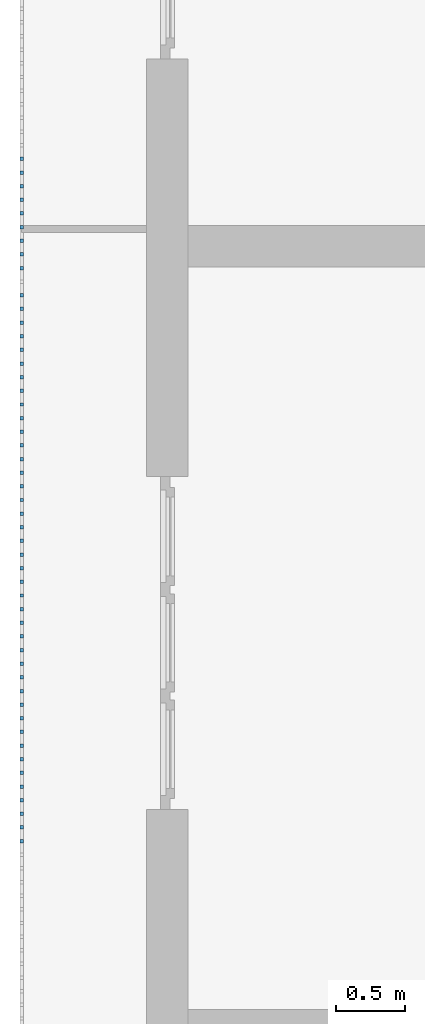
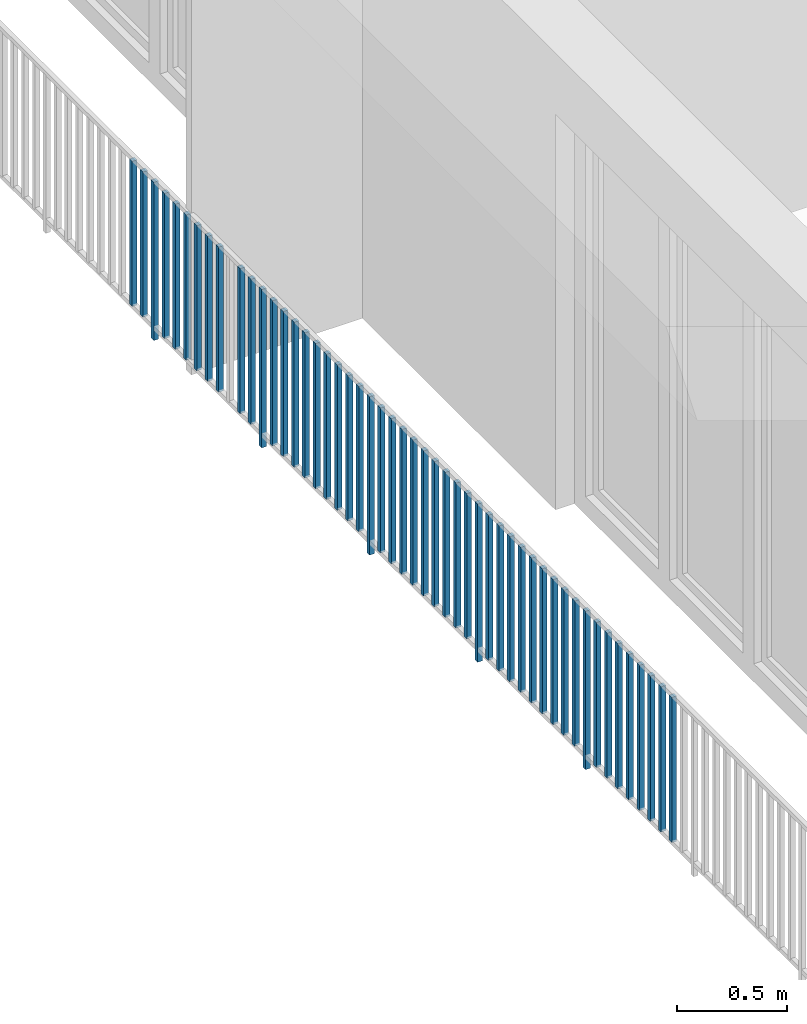
# One storey, part 37 of 54: 50 building element parts, 1 element without a shape of its own.
"""IFC4 building model written with IfcOpenShell, lengths in metres."""

import ifcopenshell
import ifcopenshell.guid

model = None  # the IFC model being written
_history = None  # IfcOwnerHistory: only IFC2X3 demands one
_inside = {}  # id of a spatial element -> (the spatial element, [elements in it])
_under = {}  # id of a project, library or spatial element -> (it, [spatial elements below it])
_declared = {}  # id of a project -> (the project, [libraries it declares])
_typed = {}  # id of a type object -> (the type object, [elements of that type])
_made_of = {}  # id of a material, layer set ... -> (it, [elements and type objects made of it])


def new_model(schema):
    """Start an empty IFC model of exactly this schema.

    Asked for "IFC4X3", IfcOpenShell would pick the latest addendum, in which some entities
    have other attributes; the version numbers below select the first issue.
    IFC2X3 requires an IfcOwnerHistory on every rooted entity: one is made here for all.
    """
    global model, _history
    if schema == "IFC4X3":
        model = ifcopenshell.file(schema_version=(4, 3, 0, 0))
    else:
        model = ifcopenshell.file(schema=schema)
    _inside.clear()
    _under.clear()
    _declared.clear()
    _typed.clear()
    _made_of.clear()
    _history = None
    if model.schema == "IFC2X3":
        org = make("IfcOrganization", Name="unknown")
        user = make(
            "IfcPersonAndOrganization",
            ThePerson=make("IfcPerson", FamilyName="unknown"),
            TheOrganization=org,
        )
        app = make(
            "IfcApplication",
            ApplicationDeveloper=org,
            Version="unknown",
            ApplicationFullName="unknown",
            ApplicationIdentifier="unknown",
        )
        _history = make(
            "IfcOwnerHistory",
            OwningUser=user,
            OwningApplication=app,
            ChangeAction="ADDED",
            CreationDate=0,
        )
    return model


def make(cls, **values):
    """One entity of the class cls with the attributes given. An attribute that is None is left unset."""
    return model.create_entity(
        cls, **{name: value for name, value in values.items() if value is not None}
    )


def entity(cls, *values):
    """Any entity or typed value of the class cls, its attributes in the order of the schema. None: left unset."""
    e = model.create_entity(cls)
    for i, value in enumerate(values):
        if value is not None:
            e[i] = value
    return e


def rooted(cls, **values):
    """An entity with a GlobalId (a new one), such as an element, a storey or a relation."""
    return make(cls, GlobalId=ifcopenshell.guid.new(), OwnerHistory=_history, **values)


def si_unit(unit_type, name, prefix=None):
    """IfcSIUnit, for example si_unit("LENGTHUNIT", "METRE", prefix="MILLI")."""
    return make("IfcSIUnit", UnitType=unit_type, Prefix=prefix, Name=name)


def converted_unit(unit_type, name, factor, base, dimensions=None, offset=None):
    """IfcConversionBasedUnit, such as the inch: factor (a typed value) times the base unit."""
    return make(
        "IfcConversionBasedUnit"
        if offset is None
        else "IfcConversionBasedUnitWithOffset",
        ConversionOffset=offset,
        Dimensions=None
        if dimensions is None
        else entity("IfcDimensionalExponents", *dimensions),
        UnitType=unit_type,
        Name=name,
        ConversionFactor=make(
            "IfcMeasureWithUnit", ValueComponent=factor, UnitComponent=base
        ),
    )


def derived_unit(unit_type, elements):
    """IfcDerivedUnit: a product of units, each with its exponent."""
    return make(
        "IfcDerivedUnit",
        Elements=[
            make("IfcDerivedUnitElement", Unit=unit, Exponent=power)
            for unit, power in elements
        ],
        UnitType=unit_type,
    )


def assignment(units):
    """IfcUnitAssignment: the units of a project."""
    return None if units is None else make("IfcUnitAssignment", Units=units)


def point(xyz):
    """IfcCartesianPoint."""
    return None if xyz is None else make("IfcCartesianPoint", Coordinates=xyz)


def direction(xyz):
    """IfcDirection."""
    return None if xyz is None else make("IfcDirection", DirectionRatios=xyz)


def frame(location, z_axis=None, x_axis=None):
    """IfcAxis2Placement3D, a coordinate frame: its origin and axes. An axis left out is left unset."""
    return make(
        "IfcAxis2Placement3D",
        Location=point(location),
        Axis=direction(z_axis),
        RefDirection=direction(x_axis),
    )


def origin_with_axes():
    """The frame at (0, 0, 0) with the z axis (0, 0, 1) and the x axis (1, 0, 0) written out."""
    return frame((0.0, 0.0, 0.0), z_axis=(0.0, 0.0, 1.0), x_axis=(1.0, 0.0, 0.0))


def place(relative_to, where):
    """IfcLocalPlacement: puts the frame where relative to a parent placement (None: the world)."""
    return make(
        "IfcLocalPlacement", PlacementRelTo=relative_to, RelativePlacement=where
    )


def context(
    kind, dimensions, precision=None, world=None, true_north=None, identifier=None
):
    """IfcGeometricRepresentationContext, for example the 3D "Model" context."""
    return make(
        "IfcGeometricRepresentationContext",
        ContextIdentifier=identifier,
        ContextType=kind,
        CoordinateSpaceDimension=dimensions,
        Precision=precision,
        WorldCoordinateSystem=world,
        TrueNorth=true_north,
    )


def subcontext(parent, identifier, kind, view, scale=None):
    """IfcGeometricRepresentationSubContext, for example "Body" below "Model"."""
    return make(
        "IfcGeometricRepresentationSubContext",
        ContextIdentifier=identifier,
        ContextType=kind,
        ParentContext=parent,
        TargetScale=scale,
        TargetView=view,
    )


def project(units=None, contexts=None):
    """IfcProject with its units and contexts."""
    return rooted(
        "IfcProject",
        Name="project",
        RepresentationContexts=contexts,
        UnitsInContext=assignment(units),
    )


def spatial(cls, under=None, at=None, **own):
    """A site, building, storey or space (cls), placed at a placement, below another one or the project."""
    s = rooted(cls, ObjectPlacement=at, **own)
    if under is not None:
        _under.setdefault(under.id(), (under, []))[1].append(s)
    return s


def point_list(points):
    """IfcCartesianPointList2D or 3D."""
    cls = (
        "IfcCartesianPointList2D" if len(points[0]) == 2 else "IfcCartesianPointList3D"
    )
    return make(cls, CoordList=points)


def polygons(points, faces, closed=None, point_numbers=None):
    """IfcPolygonalFaceSet: a face is its outer loop, then its inner loops; points numbered from 1."""
    made = []
    for loops in faces:
        if len(loops) == 1:
            made.append(make("IfcIndexedPolygonalFace", CoordIndex=loops[0]))
        else:
            made.append(
                make(
                    "IfcIndexedPolygonalFaceWithVoids",
                    CoordIndex=loops[0],
                    InnerCoordIndices=loops[1:],
                )
            )
    return make(
        "IfcPolygonalFaceSet",
        Coordinates=point_list(points),
        Closed=closed,
        Faces=made,
        PnIndex=point_numbers,
    )


def shape(context_of_items, identifier, shape_type, items):
    """IfcShapeRepresentation: the items that make up one representation, for example the "Body"."""
    return make(
        "IfcShapeRepresentation",
        ContextOfItems=context_of_items,
        RepresentationIdentifier=identifier,
        RepresentationType=shape_type,
        Items=items,
    )


def material(Name=None, Category=None):
    """IfcMaterial."""
    return make("IfcMaterial", Name=Name, Category=Category)


def made_of(thing, what):
    """Note that an element or type object is made of a material, layer set ...; save() writes the relation."""
    if what is not None:
        _made_of.setdefault(what.id(), (what, []))[1].append(thing)
    return thing


def type_object(cls, material=None, **own):
    """A type object (cls), such as IfcWallType, which elements share."""
    return made_of(rooted(cls, **own), material)


def element(
    cls,
    number,
    at=None,
    inside=None,
    cuts=None,
    type_object=None,
    material=None,
    context=None,
    identifier="Body",
    shape_type=None,
    held_by="IfcProductDefinitionShape",
    body=None,
    shapes=None,
    **own,
):
    """One element of the class cls, such as IfcWall. Its Tag is "e" and its number.

    at: its placement. inside: the storey or other place that contains it. cuts: it is an
    opening in that element (IfcRelVoidsElement). A single representation is given by context,
    identifier, shape_type and body (its items); several are given by shapes. held_by: the class
    of the entity that holds the representations. save() writes the other relations.
    """
    e = rooted(cls, Tag="e%d" % number, ObjectPlacement=at, **own)
    if body is not None:
        shapes = [shape(context, identifier, shape_type, body)]
    if shapes is not None:
        e.Representation = make(held_by, Representations=shapes)
    if inside is not None:
        _inside.setdefault(inside.id(), (inside, []))[1].append(e)
    if cuts is not None:
        rooted(
            "IfcRelVoidsElement", RelatingBuildingElement=cuts, RelatedOpeningElement=e
        )
    if type_object is not None:
        _typed.setdefault(type_object.id(), (type_object, []))[1].append(e)
    return made_of(e, material)


def aggregate(whole, parts):
    """IfcRelAggregates: a whole, such as a stair, and the parts it consists of."""
    return rooted("IfcRelAggregates", RelatingObject=whole, RelatedObjects=parts)


def save(model, path):
    """Write the relations noted so far, then the file.

    IfcRelAggregates (storeys below a building ...), IfcRelContainedInSpatialStructure (elements
    in a storey), IfcRelDefinesByType, IfcRelAssociatesMaterial and IfcRelDeclares: one each for
    every whole, place, type object, material and project.
    """
    for whole, parts in _under.values():
        aggregate(whole, parts)
    for where, things in _inside.values():
        rooted(
            "IfcRelContainedInSpatialStructure",
            RelatedElements=things,
            RelatingStructure=where,
        )
    for kind, things in _typed.values():
        rooted("IfcRelDefinesByType", RelatedObjects=things, RelatingType=kind)
    for what, things in _made_of.values():
        rooted("IfcRelAssociatesMaterial", RelatedObjects=things, RelatingMaterial=what)
    for by, libraries in _declared.values():
        rooted("IfcRelDeclares", RelatingContext=by, RelatedDefinitions=libraries)
    model.write(path)


model = new_model("IFC4")

# Units and contexts
model_context = context("Model", 3, precision=1e-05, world=origin_with_axes(), true_north=direction((0.0, 1.0)))
body_context = subcontext(model_context, "Body", "Model", "MODEL_VIEW")
ifc_project = project(units=[si_unit("LENGTHUNIT", "METRE"), si_unit("AREAUNIT", "SQUARE_METRE"), si_unit("VOLUMEUNIT", "CUBIC_METRE"), converted_unit("PLANEANGLEUNIT", "DEGREE", entity("IfcPlaneAngleMeasure", 0.0174532925199), si_unit("PLANEANGLEUNIT", "RADIAN"), dimensions=[0, 0, 0, 0, 0, 0, 0]), converted_unit("TIMEUNIT", "Year", entity("IfcTimeMeasure", 31556926.0), si_unit("TIMEUNIT", "SECOND"), dimensions=[0, 0, 1, 0, 0, 0, 0]), si_unit("MASSUNIT", "GRAM", prefix="KILO"), si_unit("THERMODYNAMICTEMPERATUREUNIT", "DEGREE_CELSIUS"), si_unit("LUMINOUSINTENSITYUNIT", "LUMEN"), si_unit("ENERGYUNIT", "JOULE", prefix="MEGA"), derived_unit("THERMALCONDUCTANCEUNIT", [(si_unit("POWERUNIT", "WATT"), 1), (si_unit("LENGTHUNIT", "METRE"), -1), (si_unit("THERMODYNAMICTEMPERATUREUNIT", "KELVIN"), -1)]), derived_unit("SPECIFICHEATCAPACITYUNIT", [(si_unit("ENERGYUNIT", "JOULE"), 1), (si_unit("MASSUNIT", "GRAM", prefix="KILO"), -1), (si_unit("THERMODYNAMICTEMPERATUREUNIT", "KELVIN"), -1)]), derived_unit("MASSDENSITYUNIT", [(si_unit("MASSUNIT", "GRAM", prefix="KILO"), 1), (si_unit("VOLUMEUNIT", "CUBIC_METRE"), -1)])], contexts=[model_context])

# Site, building, storey, space
site_placement = place(None, origin_with_axes())
site = spatial("IfcSite", under=ifc_project, at=site_placement, CompositionType="ELEMENT")
building_placement = place(site_placement, origin_with_axes())
building = spatial("IfcBuilding", under=site, at=building_placement, CompositionType="ELEMENT")
storey_placement = place(building_placement, frame((0.0, 0.0, 6.29), z_axis=(0.0, 0.0, 1.0), x_axis=(1.0, 0.0, 0.0)))
storey = spatial("IfcBuildingStorey", under=building, at=storey_placement, Name="2. Geschoss", CompositionType="ELEMENT", Elevation=6.29)
space_placement = place(storey_placement, frame((10.2378006196, 9.82118769833, 0.0), z_axis=(0.0, 0.0, 1.0), x_axis=(-1.0, 0.0, 0.0)))
space = spatial("IfcSpace", under=storey, at=space_placement, CompositionType="ELEMENT", PredefinedType="EXTERNAL")

# Railing, building element parts
railing_type = type_object("IfcRailingType", PredefinedType="NOTDEFINED")
railing_placement = place(space_placement, frame((0.0, -7.06315681498e-08, 0.0), z_axis=(0.0, 0.0, 1.0), x_axis=(-1.0, 0.0, 0.0)))
railing = element("IfcRailing", 1, at=railing_placement, inside=space, type_object=railing_type, PredefinedType="NOTDEFINED")
ifc_material = material()
building_element_part_1_placement = place(railing_placement, origin_with_axes())
building_element_part_1 = element("IfcBuildingElementPart", 2, at=building_element_part_1_placement, material=ifc_material, PredefinedType="NOTDEFINED", context=body_context, shape_type="Tessellation", body=[
    polygons([(-22.8925, -7.6825, 0.07), (-22.8675, -7.6825, 0.07), (-22.8675, -7.6825, 0.8775), (-22.8925, -7.6825, 0.8775), (-22.8925, -7.6575, 0.07), (-22.8675, -7.6575, 0.07), (-22.8675, -7.6575, 0.8775), (-22.8925, -7.6575, 0.8775)], [[[1, 2, 3, 4]], [[1, 5, 6, 2]], [[2, 6, 7, 3]], [[4, 3, 7, 8]], [[5, 1, 4, 8]], [[6, 5, 8, 7]]], closed=True),
])
building_element_part_2_placement = place(railing_placement, origin_with_axes())
building_element_part_2 = element("IfcBuildingElementPart", 3, at=building_element_part_2_placement, material=ifc_material, PredefinedType="NOTDEFINED", context=body_context, shape_type="Tessellation", body=[
    polygons([(-22.8925, -7.78083333333, 0.07), (-22.8675, -7.78083333333, 0.07), (-22.8675, -7.78083333333, 0.8775), (-22.8925, -7.78083333333, 0.8775), (-22.8925, -7.75583333333, 0.07), (-22.8675, -7.75583333333, 0.07), (-22.8675, -7.75583333333, 0.8775), (-22.8925, -7.75583333333, 0.8775)], [[[1, 2, 3, 4]], [[1, 5, 6, 2]], [[2, 6, 7, 3]], [[4, 3, 7, 8]], [[5, 1, 4, 8]], [[6, 5, 8, 7]]], closed=True),
])
building_element_part_3_placement = place(railing_placement, origin_with_axes())
building_element_part_3 = element("IfcBuildingElementPart", 4, at=building_element_part_3_placement, material=ifc_material, PredefinedType="NOTDEFINED", context=body_context, shape_type="Tessellation", body=[
    polygons([(-22.8925, -7.87916666667, 0.0), (-22.8675, -7.87916666667, 0.0), (-22.8675, -7.87916666667, 0.88), (-22.8925, -7.87916666667, 0.88), (-22.8925, -7.85416666667, 0.0), (-22.8675, -7.85416666667, 0.0), (-22.8675, -7.85416666667, 0.88), (-22.8925, -7.85416666667, 0.88)], [[[1, 2, 3, 4]], [[1, 5, 6, 2]], [[2, 6, 7, 3]], [[4, 3, 7, 8]], [[5, 1, 4, 8]], [[6, 5, 8, 7]]], closed=True),
])
building_element_part_4_placement = place(railing_placement, origin_with_axes())
building_element_part_4 = element("IfcBuildingElementPart", 5, at=building_element_part_4_placement, material=ifc_material, PredefinedType="NOTDEFINED", context=body_context, shape_type="Tessellation", body=[
    polygons([(-22.8925, -7.9775, 0.07), (-22.8675, -7.9775, 0.07), (-22.8675, -7.9775, 0.8775), (-22.8925, -7.9775, 0.8775), (-22.8925, -7.9525, 0.07), (-22.8675, -7.9525, 0.07), (-22.8675, -7.9525, 0.8775), (-22.8925, -7.9525, 0.8775)], [[[1, 2, 3, 4]], [[1, 5, 6, 2]], [[2, 6, 7, 3]], [[4, 3, 7, 8]], [[5, 1, 4, 8]], [[6, 5, 8, 7]]], closed=True),
])
building_element_part_5_placement = place(railing_placement, origin_with_axes())
building_element_part_5 = element("IfcBuildingElementPart", 6, at=building_element_part_5_placement, material=ifc_material, PredefinedType="NOTDEFINED", context=body_context, shape_type="Tessellation", body=[
    polygons([(-22.8925, -8.07583333333, 0.07), (-22.8675, -8.07583333333, 0.07), (-22.8675, -8.07583333333, 0.8775), (-22.8925, -8.07583333333, 0.8775), (-22.8925, -8.05083333333, 0.07), (-22.8675, -8.05083333333, 0.07), (-22.8675, -8.05083333333, 0.8775), (-22.8925, -8.05083333333, 0.8775)], [[[1, 2, 3, 4]], [[1, 5, 6, 2]], [[2, 6, 7, 3]], [[4, 3, 7, 8]], [[5, 1, 4, 8]], [[6, 5, 8, 7]]], closed=True),
])
building_element_part_6_placement = place(railing_placement, origin_with_axes())
building_element_part_6 = element("IfcBuildingElementPart", 7, at=building_element_part_6_placement, material=ifc_material, PredefinedType="NOTDEFINED", context=body_context, shape_type="Tessellation", body=[
    polygons([(-22.8925, -8.17416666667, 0.07), (-22.8675, -8.17416666667, 0.07), (-22.8675, -8.17416666667, 0.8775), (-22.8925, -8.17416666667, 0.8775), (-22.8925, -8.14916666667, 0.07), (-22.8675, -8.14916666667, 0.07), (-22.8675, -8.14916666667, 0.8775), (-22.8925, -8.14916666667, 0.8775)], [[[1, 2, 3, 4]], [[1, 5, 6, 2]], [[2, 6, 7, 3]], [[4, 3, 7, 8]], [[5, 1, 4, 8]], [[6, 5, 8, 7]]], closed=True),
])
building_element_part_7_placement = place(railing_placement, origin_with_axes())
building_element_part_7 = element("IfcBuildingElementPart", 8, at=building_element_part_7_placement, material=ifc_material, PredefinedType="NOTDEFINED", context=body_context, shape_type="Tessellation", body=[
    polygons([(-22.8925, -8.2725, 0.07), (-22.8675, -8.2725, 0.07), (-22.8675, -8.2725, 0.8775), (-22.8925, -8.2725, 0.8775), (-22.8925, -8.2475, 0.07), (-22.8675, -8.2475, 0.07), (-22.8675, -8.2475, 0.8775), (-22.8925, -8.2475, 0.8775)], [[[1, 2, 3, 4]], [[1, 5, 6, 2]], [[2, 6, 7, 3]], [[4, 3, 7, 8]], [[5, 1, 4, 8]], [[6, 5, 8, 7]]], closed=True),
])
building_element_part_8_placement = place(railing_placement, origin_with_axes())
building_element_part_8 = element("IfcBuildingElementPart", 9, at=building_element_part_8_placement, material=ifc_material, PredefinedType="NOTDEFINED", context=body_context, shape_type="Tessellation", body=[
    polygons([(-22.8925, -8.37083333333, 0.07), (-22.8675, -8.37083333333, 0.07), (-22.8675, -8.37083333333, 0.8775), (-22.8925, -8.37083333333, 0.8775), (-22.8925, -8.34583333333, 0.07), (-22.8675, -8.34583333333, 0.07), (-22.8675, -8.34583333333, 0.8775), (-22.8925, -8.34583333333, 0.8775)], [[[1, 2, 3, 4]], [[1, 5, 6, 2]], [[2, 6, 7, 3]], [[4, 3, 7, 8]], [[5, 1, 4, 8]], [[6, 5, 8, 7]]], closed=True),
])
building_element_part_9_placement = place(railing_placement, origin_with_axes())
building_element_part_9 = element("IfcBuildingElementPart", 10, at=building_element_part_9_placement, material=ifc_material, PredefinedType="NOTDEFINED", context=body_context, shape_type="Tessellation", body=[
    polygons([(-22.8925, -8.46916666667, 0.07), (-22.8675, -8.46916666667, 0.07), (-22.8675, -8.46916666667, 0.8775), (-22.8925, -8.46916666667, 0.8775), (-22.8925, -8.44416666667, 0.07), (-22.8675, -8.44416666667, 0.07), (-22.8675, -8.44416666667, 0.8775), (-22.8925, -8.44416666667, 0.8775)], [[[1, 2, 3, 4]], [[1, 5, 6, 2]], [[2, 6, 7, 3]], [[4, 3, 7, 8]], [[5, 1, 4, 8]], [[6, 5, 8, 7]]], closed=True),
])
building_element_part_10_placement = place(railing_placement, origin_with_axes())
building_element_part_10 = element("IfcBuildingElementPart", 11, at=building_element_part_10_placement, material=ifc_material, PredefinedType="NOTDEFINED", context=body_context, shape_type="Tessellation", body=[
    polygons([(-22.8925, -8.66583333333, 0.07), (-22.8675, -8.66583333333, 0.07), (-22.8675, -8.66583333333, 0.8775), (-22.8925, -8.66583333333, 0.8775), (-22.8925, -8.64083333333, 0.07), (-22.8675, -8.64083333333, 0.07), (-22.8675, -8.64083333333, 0.8775), (-22.8925, -8.64083333333, 0.8775)], [[[1, 2, 3, 4]], [[1, 5, 6, 2]], [[2, 6, 7, 3]], [[4, 3, 7, 8]], [[5, 1, 4, 8]], [[6, 5, 8, 7]]], closed=True),
])
building_element_part_11_placement = place(railing_placement, origin_with_axes())
building_element_part_11 = element("IfcBuildingElementPart", 12, at=building_element_part_11_placement, material=ifc_material, PredefinedType="NOTDEFINED", context=body_context, shape_type="Tessellation", body=[
    polygons([(-22.8925, -8.76416666667, 0.07), (-22.8675, -8.76416666667, 0.07), (-22.8675, -8.76416666667, 0.8775), (-22.8925, -8.76416666667, 0.8775), (-22.8925, -8.73916666667, 0.07), (-22.8675, -8.73916666667, 0.07), (-22.8675, -8.73916666667, 0.8775), (-22.8925, -8.73916666667, 0.8775)], [[[1, 2, 3, 4]], [[1, 5, 6, 2]], [[2, 6, 7, 3]], [[4, 3, 7, 8]], [[5, 1, 4, 8]], [[6, 5, 8, 7]]], closed=True),
])
building_element_part_12_placement = place(railing_placement, origin_with_axes())
building_element_part_12 = element("IfcBuildingElementPart", 13, at=building_element_part_12_placement, material=ifc_material, PredefinedType="NOTDEFINED", context=body_context, shape_type="Tessellation", body=[
    polygons([(-22.8925, -8.8625, 0.0), (-22.8675, -8.8625, 0.0), (-22.8675, -8.8625, 0.88), (-22.8925, -8.8625, 0.88), (-22.8925, -8.8375, 0.0), (-22.8675, -8.8375, 0.0), (-22.8675, -8.8375, 0.88), (-22.8925, -8.8375, 0.88)], [[[1, 2, 3, 4]], [[1, 5, 6, 2]], [[2, 6, 7, 3]], [[4, 3, 7, 8]], [[5, 1, 4, 8]], [[6, 5, 8, 7]]], closed=True),
])
building_element_part_13_placement = place(railing_placement, origin_with_axes())
building_element_part_13 = element("IfcBuildingElementPart", 14, at=building_element_part_13_placement, material=ifc_material, PredefinedType="NOTDEFINED", context=body_context, shape_type="Tessellation", body=[
    polygons([(-22.8925, -8.96083333333, 0.07), (-22.8675, -8.96083333333, 0.07), (-22.8675, -8.96083333333, 0.8775), (-22.8925, -8.96083333333, 0.8775), (-22.8925, -8.93583333333, 0.07), (-22.8675, -8.93583333333, 0.07), (-22.8675, -8.93583333333, 0.8775), (-22.8925, -8.93583333333, 0.8775)], [[[1, 2, 3, 4]], [[1, 5, 6, 2]], [[2, 6, 7, 3]], [[4, 3, 7, 8]], [[5, 1, 4, 8]], [[6, 5, 8, 7]]], closed=True),
])
building_element_part_14_placement = place(railing_placement, origin_with_axes())
building_element_part_14 = element("IfcBuildingElementPart", 15, at=building_element_part_14_placement, material=ifc_material, PredefinedType="NOTDEFINED", context=body_context, shape_type="Tessellation", body=[
    polygons([(-22.8925, -9.05916666667, 0.07), (-22.8675, -9.05916666667, 0.07), (-22.8675, -9.05916666667, 0.8775), (-22.8925, -9.05916666667, 0.8775), (-22.8925, -9.03416666667, 0.07), (-22.8675, -9.03416666667, 0.07), (-22.8675, -9.03416666667, 0.8775), (-22.8925, -9.03416666667, 0.8775)], [[[1, 2, 3, 4]], [[1, 5, 6, 2]], [[2, 6, 7, 3]], [[4, 3, 7, 8]], [[5, 1, 4, 8]], [[6, 5, 8, 7]]], closed=True),
])
building_element_part_15_placement = place(railing_placement, origin_with_axes())
building_element_part_15 = element("IfcBuildingElementPart", 16, at=building_element_part_15_placement, material=ifc_material, PredefinedType="NOTDEFINED", context=body_context, shape_type="Tessellation", body=[
    polygons([(-22.8925, -9.1575, 0.07), (-22.8675, -9.1575, 0.07), (-22.8675, -9.1575, 0.8775), (-22.8925, -9.1575, 0.8775), (-22.8925, -9.1325, 0.07), (-22.8675, -9.1325, 0.07), (-22.8675, -9.1325, 0.8775), (-22.8925, -9.1325, 0.8775)], [[[1, 2, 3, 4]], [[1, 5, 6, 2]], [[2, 6, 7, 3]], [[4, 3, 7, 8]], [[5, 1, 4, 8]], [[6, 5, 8, 7]]], closed=True),
])
building_element_part_16_placement = place(railing_placement, origin_with_axes())
building_element_part_16 = element("IfcBuildingElementPart", 17, at=building_element_part_16_placement, material=ifc_material, PredefinedType="NOTDEFINED", context=body_context, shape_type="Tessellation", body=[
    polygons([(-22.8925, -9.25583333333, 0.07), (-22.8675, -9.25583333333, 0.07), (-22.8675, -9.25583333333, 0.8775), (-22.8925, -9.25583333333, 0.8775), (-22.8925, -9.23083333333, 0.07), (-22.8675, -9.23083333333, 0.07), (-22.8675, -9.23083333333, 0.8775), (-22.8925, -9.23083333333, 0.8775)], [[[1, 2, 3, 4]], [[1, 5, 6, 2]], [[2, 6, 7, 3]], [[4, 3, 7, 8]], [[5, 1, 4, 8]], [[6, 5, 8, 7]]], closed=True),
])
building_element_part_17_placement = place(railing_placement, origin_with_axes())
building_element_part_17 = element("IfcBuildingElementPart", 18, at=building_element_part_17_placement, material=ifc_material, PredefinedType="NOTDEFINED", context=body_context, shape_type="Tessellation", body=[
    polygons([(-22.8925, -9.35416666667, 0.07), (-22.8675, -9.35416666667, 0.07), (-22.8675, -9.35416666667, 0.8775), (-22.8925, -9.35416666667, 0.8775), (-22.8925, -9.32916666667, 0.07), (-22.8675, -9.32916666667, 0.07), (-22.8675, -9.32916666667, 0.8775), (-22.8925, -9.32916666667, 0.8775)], [[[1, 2, 3, 4]], [[1, 5, 6, 2]], [[2, 6, 7, 3]], [[4, 3, 7, 8]], [[5, 1, 4, 8]], [[6, 5, 8, 7]]], closed=True),
])
building_element_part_18_placement = place(railing_placement, origin_with_axes())
building_element_part_18 = element("IfcBuildingElementPart", 19, at=building_element_part_18_placement, material=ifc_material, PredefinedType="NOTDEFINED", context=body_context, shape_type="Tessellation", body=[
    polygons([(-22.8925, -9.4525, 0.07), (-22.8675, -9.4525, 0.07), (-22.8675, -9.4525, 0.8775), (-22.8925, -9.4525, 0.8775), (-22.8925, -9.4275, 0.07), (-22.8675, -9.4275, 0.07), (-22.8675, -9.4275, 0.8775), (-22.8925, -9.4275, 0.8775)], [[[1, 2, 3, 4]], [[1, 5, 6, 2]], [[2, 6, 7, 3]], [[4, 3, 7, 8]], [[5, 1, 4, 8]], [[6, 5, 8, 7]]], closed=True),
])
building_element_part_19_placement = place(railing_placement, origin_with_axes())
building_element_part_19 = element("IfcBuildingElementPart", 20, at=building_element_part_19_placement, material=ifc_material, PredefinedType="NOTDEFINED", context=body_context, shape_type="Tessellation", body=[
    polygons([(-22.8925, -9.55083333333, 0.07), (-22.8675, -9.55083333333, 0.07), (-22.8675, -9.55083333333, 0.8775), (-22.8925, -9.55083333333, 0.8775), (-22.8925, -9.52583333333, 0.07), (-22.8675, -9.52583333333, 0.07), (-22.8675, -9.52583333333, 0.8775), (-22.8925, -9.52583333333, 0.8775)], [[[1, 2, 3, 4]], [[1, 5, 6, 2]], [[2, 6, 7, 3]], [[4, 3, 7, 8]], [[5, 1, 4, 8]], [[6, 5, 8, 7]]], closed=True),
])
building_element_part_20_placement = place(railing_placement, origin_with_axes())
building_element_part_20 = element("IfcBuildingElementPart", 21, at=building_element_part_20_placement, material=ifc_material, PredefinedType="NOTDEFINED", context=body_context, shape_type="Tessellation", body=[
    polygons([(-22.8925, -9.64916666667, 0.07), (-22.8675, -9.64916666667, 0.07), (-22.8675, -9.64916666667, 0.8775), (-22.8925, -9.64916666667, 0.8775), (-22.8925, -9.62416666667, 0.07), (-22.8675, -9.62416666667, 0.07), (-22.8675, -9.62416666667, 0.8775), (-22.8925, -9.62416666667, 0.8775)], [[[1, 2, 3, 4]], [[1, 5, 6, 2]], [[2, 6, 7, 3]], [[4, 3, 7, 8]], [[5, 1, 4, 8]], [[6, 5, 8, 7]]], closed=True),
])
building_element_part_21_placement = place(railing_placement, origin_with_axes())
building_element_part_21 = element("IfcBuildingElementPart", 22, at=building_element_part_21_placement, material=ifc_material, PredefinedType="NOTDEFINED", context=body_context, shape_type="Tessellation", body=[
    polygons([(-22.8925, -9.7475, 0.07), (-22.8675, -9.7475, 0.07), (-22.8675, -9.7475, 0.8775), (-22.8925, -9.7475, 0.8775), (-22.8925, -9.7225, 0.07), (-22.8675, -9.7225, 0.07), (-22.8675, -9.7225, 0.8775), (-22.8925, -9.7225, 0.8775)], [[[1, 2, 3, 4]], [[1, 5, 6, 2]], [[2, 6, 7, 3]], [[4, 3, 7, 8]], [[5, 1, 4, 8]], [[6, 5, 8, 7]]], closed=True),
])
building_element_part_22_placement = place(railing_placement, origin_with_axes())
building_element_part_22 = element("IfcBuildingElementPart", 23, at=building_element_part_22_placement, material=ifc_material, PredefinedType="NOTDEFINED", context=body_context, shape_type="Tessellation", body=[
    polygons([(-22.8925, -9.84583333333, 0.0), (-22.8675, -9.84583333333, 0.0), (-22.8675, -9.84583333333, 0.88), (-22.8925, -9.84583333333, 0.88), (-22.8925, -9.82083333333, 0.0), (-22.8675, -9.82083333333, 0.0), (-22.8675, -9.82083333333, 0.88), (-22.8925, -9.82083333333, 0.88)], [[[1, 2, 3, 4]], [[1, 5, 6, 2]], [[2, 6, 7, 3]], [[4, 3, 7, 8]], [[5, 1, 4, 8]], [[6, 5, 8, 7]]], closed=True),
])
building_element_part_23_placement = place(railing_placement, origin_with_axes())
building_element_part_23 = element("IfcBuildingElementPart", 24, at=building_element_part_23_placement, material=ifc_material, PredefinedType="NOTDEFINED", context=body_context, shape_type="Tessellation", body=[
    polygons([(-22.8925, -9.94416666667, 0.07), (-22.8675, -9.94416666667, 0.07), (-22.8675, -9.94416666667, 0.8775), (-22.8925, -9.94416666667, 0.8775), (-22.8925, -9.91916666667, 0.07), (-22.8675, -9.91916666667, 0.07), (-22.8675, -9.91916666667, 0.8775), (-22.8925, -9.91916666667, 0.8775)], [[[1, 2, 3, 4]], [[1, 5, 6, 2]], [[2, 6, 7, 3]], [[4, 3, 7, 8]], [[5, 1, 4, 8]], [[6, 5, 8, 7]]], closed=True),
])
building_element_part_24_placement = place(railing_placement, origin_with_axes())
building_element_part_24 = element("IfcBuildingElementPart", 25, at=building_element_part_24_placement, material=ifc_material, PredefinedType="NOTDEFINED", context=body_context, shape_type="Tessellation", body=[
    polygons([(-22.8925, -10.0425, 0.07), (-22.8675, -10.0425, 0.07), (-22.8675, -10.0425, 0.8775), (-22.8925, -10.0425, 0.8775), (-22.8925, -10.0175, 0.07), (-22.8675, -10.0175, 0.07), (-22.8675, -10.0175, 0.8775), (-22.8925, -10.0175, 0.8775)], [[[1, 2, 3, 4]], [[1, 5, 6, 2]], [[2, 6, 7, 3]], [[4, 3, 7, 8]], [[5, 1, 4, 8]], [[6, 5, 8, 7]]], closed=True),
])
building_element_part_25_placement = place(railing_placement, origin_with_axes())
building_element_part_25 = element("IfcBuildingElementPart", 26, at=building_element_part_25_placement, material=ifc_material, PredefinedType="NOTDEFINED", context=body_context, shape_type="Tessellation", body=[
    polygons([(-22.8925, -10.1408333333, 0.07), (-22.8675, -10.1408333333, 0.07), (-22.8675, -10.1408333333, 0.8775), (-22.8925, -10.1408333333, 0.8775), (-22.8925, -10.1158333333, 0.07), (-22.8675, -10.1158333333, 0.07), (-22.8675, -10.1158333333, 0.8775), (-22.8925, -10.1158333333, 0.8775)], [[[1, 2, 3, 4]], [[1, 5, 6, 2]], [[2, 6, 7, 3]], [[4, 3, 7, 8]], [[5, 1, 4, 8]], [[6, 5, 8, 7]]], closed=True),
])
building_element_part_26_placement = place(railing_placement, origin_with_axes())
building_element_part_26 = element("IfcBuildingElementPart", 27, at=building_element_part_26_placement, material=ifc_material, PredefinedType="NOTDEFINED", context=body_context, shape_type="Tessellation", body=[
    polygons([(-22.8925, -10.2391666667, 0.07), (-22.8675, -10.2391666667, 0.07), (-22.8675, -10.2391666667, 0.8775), (-22.8925, -10.2391666667, 0.8775), (-22.8925, -10.2141666667, 0.07), (-22.8675, -10.2141666667, 0.07), (-22.8675, -10.2141666667, 0.8775), (-22.8925, -10.2141666667, 0.8775)], [[[1, 2, 3, 4]], [[1, 5, 6, 2]], [[2, 6, 7, 3]], [[4, 3, 7, 8]], [[5, 1, 4, 8]], [[6, 5, 8, 7]]], closed=True),
])
building_element_part_27_placement = place(railing_placement, origin_with_axes())
building_element_part_27 = element("IfcBuildingElementPart", 28, at=building_element_part_27_placement, material=ifc_material, PredefinedType="NOTDEFINED", context=body_context, shape_type="Tessellation", body=[
    polygons([(-22.8925, -10.3375, 0.07), (-22.8675, -10.3375, 0.07), (-22.8675, -10.3375, 0.8775), (-22.8925, -10.3375, 0.8775), (-22.8925, -10.3125, 0.07), (-22.8675, -10.3125, 0.07), (-22.8675, -10.3125, 0.8775), (-22.8925, -10.3125, 0.8775)], [[[1, 2, 3, 4]], [[1, 5, 6, 2]], [[2, 6, 7, 3]], [[4, 3, 7, 8]], [[5, 1, 4, 8]], [[6, 5, 8, 7]]], closed=True),
])
building_element_part_28_placement = place(railing_placement, origin_with_axes())
building_element_part_28 = element("IfcBuildingElementPart", 29, at=building_element_part_28_placement, material=ifc_material, PredefinedType="NOTDEFINED", context=body_context, shape_type="Tessellation", body=[
    polygons([(-22.8925, -10.4358333333, 0.07), (-22.8675, -10.4358333333, 0.07), (-22.8675, -10.4358333333, 0.8775), (-22.8925, -10.4358333333, 0.8775), (-22.8925, -10.4108333333, 0.07), (-22.8675, -10.4108333333, 0.07), (-22.8675, -10.4108333333, 0.8775), (-22.8925, -10.4108333333, 0.8775)], [[[1, 2, 3, 4]], [[1, 5, 6, 2]], [[2, 6, 7, 3]], [[4, 3, 7, 8]], [[5, 1, 4, 8]], [[6, 5, 8, 7]]], closed=True),
])
building_element_part_29_placement = place(railing_placement, origin_with_axes())
building_element_part_29 = element("IfcBuildingElementPart", 30, at=building_element_part_29_placement, material=ifc_material, PredefinedType="NOTDEFINED", context=body_context, shape_type="Tessellation", body=[
    polygons([(-22.8925, -10.5341666667, 0.07), (-22.8675, -10.5341666667, 0.07), (-22.8675, -10.5341666667, 0.8775), (-22.8925, -10.5341666667, 0.8775), (-22.8925, -10.5091666667, 0.07), (-22.8675, -10.5091666667, 0.07), (-22.8675, -10.5091666667, 0.8775), (-22.8925, -10.5091666667, 0.8775)], [[[1, 2, 3, 4]], [[1, 5, 6, 2]], [[2, 6, 7, 3]], [[4, 3, 7, 8]], [[5, 1, 4, 8]], [[6, 5, 8, 7]]], closed=True),
])
building_element_part_30_placement = place(railing_placement, origin_with_axes())
building_element_part_30 = element("IfcBuildingElementPart", 31, at=building_element_part_30_placement, material=ifc_material, PredefinedType="NOTDEFINED", context=body_context, shape_type="Tessellation", body=[
    polygons([(-22.8925, -10.6325, 0.07), (-22.8675, -10.6325, 0.07), (-22.8675, -10.6325, 0.8775), (-22.8925, -10.6325, 0.8775), (-22.8925, -10.6075, 0.07), (-22.8675, -10.6075, 0.07), (-22.8675, -10.6075, 0.8775), (-22.8925, -10.6075, 0.8775)], [[[1, 2, 3, 4]], [[1, 5, 6, 2]], [[2, 6, 7, 3]], [[4, 3, 7, 8]], [[5, 1, 4, 8]], [[6, 5, 8, 7]]], closed=True),
])
building_element_part_31_placement = place(railing_placement, origin_with_axes())
building_element_part_31 = element("IfcBuildingElementPart", 32, at=building_element_part_31_placement, material=ifc_material, PredefinedType="NOTDEFINED", context=body_context, shape_type="Tessellation", body=[
    polygons([(-22.8925, -10.7308333333, 0.07), (-22.8675, -10.7308333333, 0.07), (-22.8675, -10.7308333333, 0.8775), (-22.8925, -10.7308333333, 0.8775), (-22.8925, -10.7058333333, 0.07), (-22.8675, -10.7058333333, 0.07), (-22.8675, -10.7058333333, 0.8775), (-22.8925, -10.7058333333, 0.8775)], [[[1, 2, 3, 4]], [[1, 5, 6, 2]], [[2, 6, 7, 3]], [[4, 3, 7, 8]], [[5, 1, 4, 8]], [[6, 5, 8, 7]]], closed=True),
])
building_element_part_32_placement = place(railing_placement, origin_with_axes())
building_element_part_32 = element("IfcBuildingElementPart", 33, at=building_element_part_32_placement, material=ifc_material, PredefinedType="NOTDEFINED", context=body_context, shape_type="Tessellation", body=[
    polygons([(-22.8925, -10.8291666667, 0.0), (-22.8675, -10.8291666667, 0.0), (-22.8675, -10.8291666667, 0.88), (-22.8925, -10.8291666667, 0.88), (-22.8925, -10.8041666667, 0.0), (-22.8675, -10.8041666667, 0.0), (-22.8675, -10.8041666667, 0.88), (-22.8925, -10.8041666667, 0.88)], [[[1, 2, 3, 4]], [[1, 5, 6, 2]], [[2, 6, 7, 3]], [[4, 3, 7, 8]], [[5, 1, 4, 8]], [[6, 5, 8, 7]]], closed=True),
])
building_element_part_33_placement = place(railing_placement, origin_with_axes())
building_element_part_33 = element("IfcBuildingElementPart", 34, at=building_element_part_33_placement, material=ifc_material, PredefinedType="NOTDEFINED", context=body_context, shape_type="Tessellation", body=[
    polygons([(-22.8925, -10.9275, 0.07), (-22.8675, -10.9275, 0.07), (-22.8675, -10.9275, 0.8775), (-22.8925, -10.9275, 0.8775), (-22.8925, -10.9025, 0.07), (-22.8675, -10.9025, 0.07), (-22.8675, -10.9025, 0.8775), (-22.8925, -10.9025, 0.8775)], [[[1, 2, 3, 4]], [[1, 5, 6, 2]], [[2, 6, 7, 3]], [[4, 3, 7, 8]], [[5, 1, 4, 8]], [[6, 5, 8, 7]]], closed=True),
])
building_element_part_34_placement = place(railing_placement, origin_with_axes())
building_element_part_34 = element("IfcBuildingElementPart", 35, at=building_element_part_34_placement, material=ifc_material, PredefinedType="NOTDEFINED", context=body_context, shape_type="Tessellation", body=[
    polygons([(-22.8925, -11.0258333333, 0.07), (-22.8675, -11.0258333333, 0.07), (-22.8675, -11.0258333333, 0.8775), (-22.8925, -11.0258333333, 0.8775), (-22.8925, -11.0008333333, 0.07), (-22.8675, -11.0008333333, 0.07), (-22.8675, -11.0008333333, 0.8775), (-22.8925, -11.0008333333, 0.8775)], [[[1, 2, 3, 4]], [[1, 5, 6, 2]], [[2, 6, 7, 3]], [[4, 3, 7, 8]], [[5, 1, 4, 8]], [[6, 5, 8, 7]]], closed=True),
])
building_element_part_35_placement = place(railing_placement, origin_with_axes())
building_element_part_35 = element("IfcBuildingElementPart", 36, at=building_element_part_35_placement, material=ifc_material, PredefinedType="NOTDEFINED", context=body_context, shape_type="Tessellation", body=[
    polygons([(-22.8925, -11.1241666667, 0.07), (-22.8675, -11.1241666667, 0.07), (-22.8675, -11.1241666667, 0.8775), (-22.8925, -11.1241666667, 0.8775), (-22.8925, -11.0991666667, 0.07), (-22.8675, -11.0991666667, 0.07), (-22.8675, -11.0991666667, 0.8775), (-22.8925, -11.0991666667, 0.8775)], [[[1, 2, 3, 4]], [[1, 5, 6, 2]], [[2, 6, 7, 3]], [[4, 3, 7, 8]], [[5, 1, 4, 8]], [[6, 5, 8, 7]]], closed=True),
])
building_element_part_36_placement = place(railing_placement, origin_with_axes())
building_element_part_36 = element("IfcBuildingElementPart", 37, at=building_element_part_36_placement, material=ifc_material, PredefinedType="NOTDEFINED", context=body_context, shape_type="Tessellation", body=[
    polygons([(-22.8925, -11.2225, 0.07), (-22.8675, -11.2225, 0.07), (-22.8675, -11.2225, 0.8775), (-22.8925, -11.2225, 0.8775), (-22.8925, -11.1975, 0.07), (-22.8675, -11.1975, 0.07), (-22.8675, -11.1975, 0.8775), (-22.8925, -11.1975, 0.8775)], [[[1, 2, 3, 4]], [[1, 5, 6, 2]], [[2, 6, 7, 3]], [[4, 3, 7, 8]], [[5, 1, 4, 8]], [[6, 5, 8, 7]]], closed=True),
])
building_element_part_37_placement = place(railing_placement, origin_with_axes())
building_element_part_37 = element("IfcBuildingElementPart", 38, at=building_element_part_37_placement, material=ifc_material, PredefinedType="NOTDEFINED", context=body_context, shape_type="Tessellation", body=[
    polygons([(-22.8925, -11.3208333333, 0.07), (-22.8675, -11.3208333333, 0.07), (-22.8675, -11.3208333333, 0.8775), (-22.8925, -11.3208333333, 0.8775), (-22.8925, -11.2958333333, 0.07), (-22.8675, -11.2958333333, 0.07), (-22.8675, -11.2958333333, 0.8775), (-22.8925, -11.2958333333, 0.8775)], [[[1, 2, 3, 4]], [[1, 5, 6, 2]], [[2, 6, 7, 3]], [[4, 3, 7, 8]], [[5, 1, 4, 8]], [[6, 5, 8, 7]]], closed=True),
])
building_element_part_38_placement = place(railing_placement, origin_with_axes())
building_element_part_38 = element("IfcBuildingElementPart", 39, at=building_element_part_38_placement, material=ifc_material, PredefinedType="NOTDEFINED", context=body_context, shape_type="Tessellation", body=[
    polygons([(-22.8925, -11.4191666667, 0.07), (-22.8675, -11.4191666667, 0.07), (-22.8675, -11.4191666667, 0.8775), (-22.8925, -11.4191666667, 0.8775), (-22.8925, -11.3941666667, 0.07), (-22.8675, -11.3941666667, 0.07), (-22.8675, -11.3941666667, 0.8775), (-22.8925, -11.3941666667, 0.8775)], [[[1, 2, 3, 4]], [[1, 5, 6, 2]], [[2, 6, 7, 3]], [[4, 3, 7, 8]], [[5, 1, 4, 8]], [[6, 5, 8, 7]]], closed=True),
])
building_element_part_39_placement = place(railing_placement, origin_with_axes())
building_element_part_39 = element("IfcBuildingElementPart", 40, at=building_element_part_39_placement, material=ifc_material, PredefinedType="NOTDEFINED", context=body_context, shape_type="Tessellation", body=[
    polygons([(-22.8925, -11.5175, 0.07), (-22.8675, -11.5175, 0.07), (-22.8675, -11.5175, 0.8775), (-22.8925, -11.5175, 0.8775), (-22.8925, -11.4925, 0.07), (-22.8675, -11.4925, 0.07), (-22.8675, -11.4925, 0.8775), (-22.8925, -11.4925, 0.8775)], [[[1, 2, 3, 4]], [[1, 5, 6, 2]], [[2, 6, 7, 3]], [[4, 3, 7, 8]], [[5, 1, 4, 8]], [[6, 5, 8, 7]]], closed=True),
])
building_element_part_40_placement = place(railing_placement, origin_with_axes())
building_element_part_40 = element("IfcBuildingElementPart", 41, at=building_element_part_40_placement, material=ifc_material, PredefinedType="NOTDEFINED", context=body_context, shape_type="Tessellation", body=[
    polygons([(-22.8925, -11.6158333333, 0.07), (-22.8675, -11.6158333333, 0.07), (-22.8675, -11.6158333333, 0.8775), (-22.8925, -11.6158333333, 0.8775), (-22.8925, -11.5908333333, 0.07), (-22.8675, -11.5908333333, 0.07), (-22.8675, -11.5908333333, 0.8775), (-22.8925, -11.5908333333, 0.8775)], [[[1, 2, 3, 4]], [[1, 5, 6, 2]], [[2, 6, 7, 3]], [[4, 3, 7, 8]], [[5, 1, 4, 8]], [[6, 5, 8, 7]]], closed=True),
])
building_element_part_41_placement = place(railing_placement, origin_with_axes())
building_element_part_41 = element("IfcBuildingElementPart", 42, at=building_element_part_41_placement, material=ifc_material, PredefinedType="NOTDEFINED", context=body_context, shape_type="Tessellation", body=[
    polygons([(-22.8925, -11.7141666667, 0.07), (-22.8675, -11.7141666667, 0.07), (-22.8675, -11.7141666667, 0.8775), (-22.8925, -11.7141666667, 0.8775), (-22.8925, -11.6891666667, 0.07), (-22.8675, -11.6891666667, 0.07), (-22.8675, -11.6891666667, 0.8775), (-22.8925, -11.6891666667, 0.8775)], [[[1, 2, 3, 4]], [[1, 5, 6, 2]], [[2, 6, 7, 3]], [[4, 3, 7, 8]], [[5, 1, 4, 8]], [[6, 5, 8, 7]]], closed=True),
])
building_element_part_42_placement = place(railing_placement, origin_with_axes())
building_element_part_42 = element("IfcBuildingElementPart", 43, at=building_element_part_42_placement, material=ifc_material, PredefinedType="NOTDEFINED", context=body_context, shape_type="Tessellation", body=[
    polygons([(-22.8925, -11.8125, 0.0), (-22.8675, -11.8125, 0.0), (-22.8675, -11.8125, 0.88), (-22.8925, -11.8125, 0.88), (-22.8925, -11.7875, 0.0), (-22.8675, -11.7875, 0.0), (-22.8675, -11.7875, 0.88), (-22.8925, -11.7875, 0.88)], [[[1, 2, 3, 4]], [[1, 5, 6, 2]], [[2, 6, 7, 3]], [[4, 3, 7, 8]], [[5, 1, 4, 8]], [[6, 5, 8, 7]]], closed=True),
])
building_element_part_43_placement = place(railing_placement, origin_with_axes())
building_element_part_43 = element("IfcBuildingElementPart", 44, at=building_element_part_43_placement, material=ifc_material, PredefinedType="NOTDEFINED", context=body_context, shape_type="Tessellation", body=[
    polygons([(-22.8925, -11.9108333333, 0.07), (-22.8675, -11.9108333333, 0.07), (-22.8675, -11.9108333333, 0.8775), (-22.8925, -11.9108333333, 0.8775), (-22.8925, -11.8858333333, 0.07), (-22.8675, -11.8858333333, 0.07), (-22.8675, -11.8858333333, 0.8775), (-22.8925, -11.8858333333, 0.8775)], [[[1, 2, 3, 4]], [[1, 5, 6, 2]], [[2, 6, 7, 3]], [[4, 3, 7, 8]], [[5, 1, 4, 8]], [[6, 5, 8, 7]]], closed=True),
])
building_element_part_44_placement = place(railing_placement, origin_with_axes())
building_element_part_44 = element("IfcBuildingElementPart", 45, at=building_element_part_44_placement, material=ifc_material, PredefinedType="NOTDEFINED", context=body_context, shape_type="Tessellation", body=[
    polygons([(-22.8925, -12.0091666667, 0.07), (-22.8675, -12.0091666667, 0.07), (-22.8675, -12.0091666667, 0.8775), (-22.8925, -12.0091666667, 0.8775), (-22.8925, -11.9841666667, 0.07), (-22.8675, -11.9841666667, 0.07), (-22.8675, -11.9841666667, 0.8775), (-22.8925, -11.9841666667, 0.8775)], [[[1, 2, 3, 4]], [[1, 5, 6, 2]], [[2, 6, 7, 3]], [[4, 3, 7, 8]], [[5, 1, 4, 8]], [[6, 5, 8, 7]]], closed=True),
])
building_element_part_45_placement = place(railing_placement, origin_with_axes())
building_element_part_45 = element("IfcBuildingElementPart", 46, at=building_element_part_45_placement, material=ifc_material, PredefinedType="NOTDEFINED", context=body_context, shape_type="Tessellation", body=[
    polygons([(-22.8925, -12.1075, 0.07), (-22.8675, -12.1075, 0.07), (-22.8675, -12.1075, 0.8775), (-22.8925, -12.1075, 0.8775), (-22.8925, -12.0825, 0.07), (-22.8675, -12.0825, 0.07), (-22.8675, -12.0825, 0.8775), (-22.8925, -12.0825, 0.8775)], [[[1, 2, 3, 4]], [[1, 5, 6, 2]], [[2, 6, 7, 3]], [[4, 3, 7, 8]], [[5, 1, 4, 8]], [[6, 5, 8, 7]]], closed=True),
])
building_element_part_46_placement = place(railing_placement, origin_with_axes())
building_element_part_46 = element("IfcBuildingElementPart", 47, at=building_element_part_46_placement, material=ifc_material, PredefinedType="NOTDEFINED", context=body_context, shape_type="Tessellation", body=[
    polygons([(-22.8925, -12.2058333333, 0.07), (-22.8675, -12.2058333333, 0.07), (-22.8675, -12.2058333333, 0.8775), (-22.8925, -12.2058333333, 0.8775), (-22.8925, -12.1808333333, 0.07), (-22.8675, -12.1808333333, 0.07), (-22.8675, -12.1808333333, 0.8775), (-22.8925, -12.1808333333, 0.8775)], [[[1, 2, 3, 4]], [[1, 5, 6, 2]], [[2, 6, 7, 3]], [[4, 3, 7, 8]], [[5, 1, 4, 8]], [[6, 5, 8, 7]]], closed=True),
])
building_element_part_47_placement = place(railing_placement, origin_with_axes())
building_element_part_47 = element("IfcBuildingElementPart", 48, at=building_element_part_47_placement, material=ifc_material, PredefinedType="NOTDEFINED", context=body_context, shape_type="Tessellation", body=[
    polygons([(-22.8925, -12.3041666667, 0.07), (-22.8675, -12.3041666667, 0.07), (-22.8675, -12.3041666667, 0.8775), (-22.8925, -12.3041666667, 0.8775), (-22.8925, -12.2791666667, 0.07), (-22.8675, -12.2791666667, 0.07), (-22.8675, -12.2791666667, 0.8775), (-22.8925, -12.2791666667, 0.8775)], [[[1, 2, 3, 4]], [[1, 5, 6, 2]], [[2, 6, 7, 3]], [[4, 3, 7, 8]], [[5, 1, 4, 8]], [[6, 5, 8, 7]]], closed=True),
])
building_element_part_48_placement = place(railing_placement, origin_with_axes())
building_element_part_48 = element("IfcBuildingElementPart", 49, at=building_element_part_48_placement, material=ifc_material, PredefinedType="NOTDEFINED", context=body_context, shape_type="Tessellation", body=[
    polygons([(-22.8925, -12.4025, 0.07), (-22.8675, -12.4025, 0.07), (-22.8675, -12.4025, 0.8775), (-22.8925, -12.4025, 0.8775), (-22.8925, -12.3775, 0.07), (-22.8675, -12.3775, 0.07), (-22.8675, -12.3775, 0.8775), (-22.8925, -12.3775, 0.8775)], [[[1, 2, 3, 4]], [[1, 5, 6, 2]], [[2, 6, 7, 3]], [[4, 3, 7, 8]], [[5, 1, 4, 8]], [[6, 5, 8, 7]]], closed=True),
])
building_element_part_49_placement = place(railing_placement, origin_with_axes())
building_element_part_49 = element("IfcBuildingElementPart", 50, at=building_element_part_49_placement, material=ifc_material, PredefinedType="NOTDEFINED", context=body_context, shape_type="Tessellation", body=[
    polygons([(-22.8925, -12.5008333333, 0.07), (-22.8675, -12.5008333333, 0.07), (-22.8675, -12.5008333333, 0.8775), (-22.8925, -12.5008333333, 0.8775), (-22.8925, -12.4758333333, 0.07), (-22.8675, -12.4758333333, 0.07), (-22.8675, -12.4758333333, 0.8775), (-22.8925, -12.4758333333, 0.8775)], [[[1, 2, 3, 4]], [[1, 5, 6, 2]], [[2, 6, 7, 3]], [[4, 3, 7, 8]], [[5, 1, 4, 8]], [[6, 5, 8, 7]]], closed=True),
])
building_element_part_50_placement = place(railing_placement, origin_with_axes())
building_element_part_50 = element("IfcBuildingElementPart", 51, at=building_element_part_50_placement, material=ifc_material, PredefinedType="NOTDEFINED", context=body_context, shape_type="Tessellation", body=[
    polygons([(-22.8925, -12.5991666667, 0.07), (-22.8675, -12.5991666667, 0.07), (-22.8675, -12.5991666667, 0.8775), (-22.8925, -12.5991666667, 0.8775), (-22.8925, -12.5741666667, 0.07), (-22.8675, -12.5741666667, 0.07), (-22.8675, -12.5741666667, 0.8775), (-22.8925, -12.5741666667, 0.8775)], [[[1, 2, 3, 4]], [[1, 5, 6, 2]], [[2, 6, 7, 3]], [[4, 3, 7, 8]], [[5, 1, 4, 8]], [[6, 5, 8, 7]]], closed=True),
])
aggregate(railing, [building_element_part_1, building_element_part_2, building_element_part_3, building_element_part_4, building_element_part_5, building_element_part_6, building_element_part_7, building_element_part_8, building_element_part_9, building_element_part_10, building_element_part_11, building_element_part_12, building_element_part_13, building_element_part_14, building_element_part_15, building_element_part_16, building_element_part_17, building_element_part_18, building_element_part_19, building_element_part_20, building_element_part_21, building_element_part_22, building_element_part_23, building_element_part_24, building_element_part_25, building_element_part_26, building_element_part_27, building_element_part_28, building_element_part_29, building_element_part_30, building_element_part_31, building_element_part_32, building_element_part_33, building_element_part_34, building_element_part_35, building_element_part_36, building_element_part_37, building_element_part_38, building_element_part_39, building_element_part_40, building_element_part_41, building_element_part_42, building_element_part_43, building_element_part_44, building_element_part_45, building_element_part_46, building_element_part_47, building_element_part_48, building_element_part_49, building_element_part_50])

save(model, "model.ifc")
